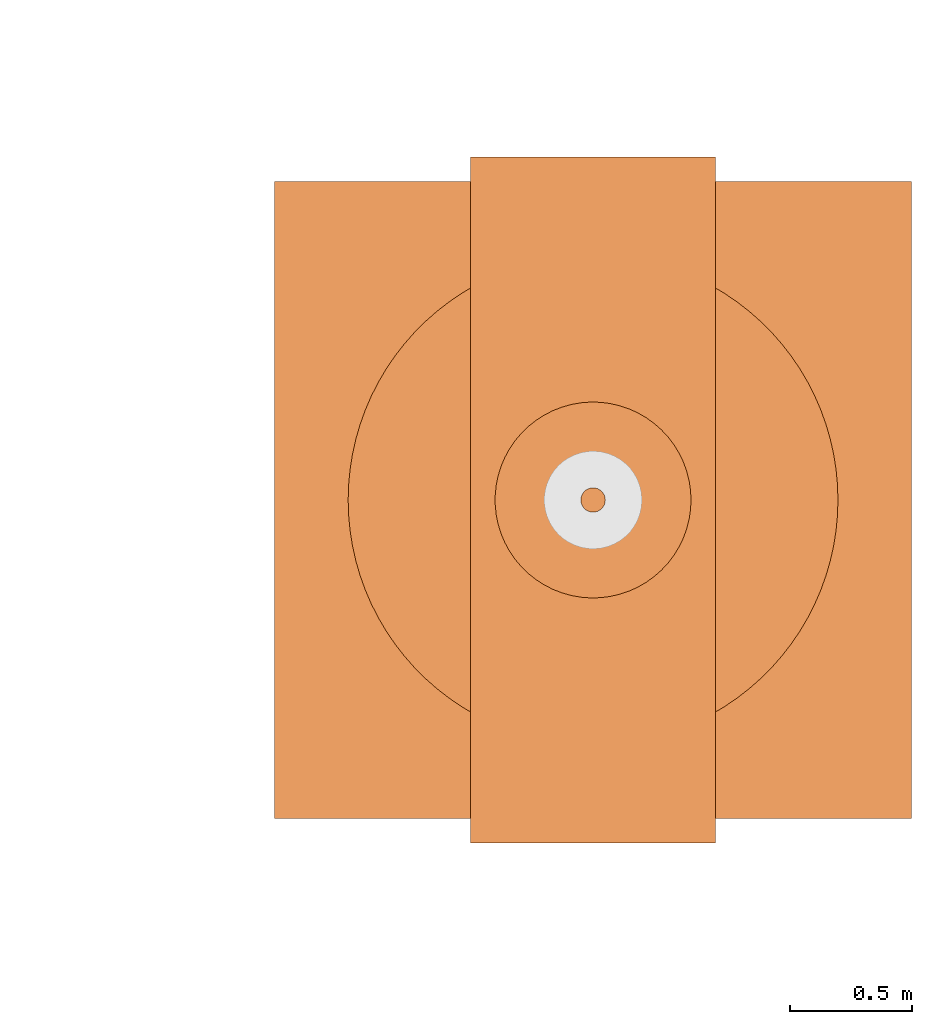
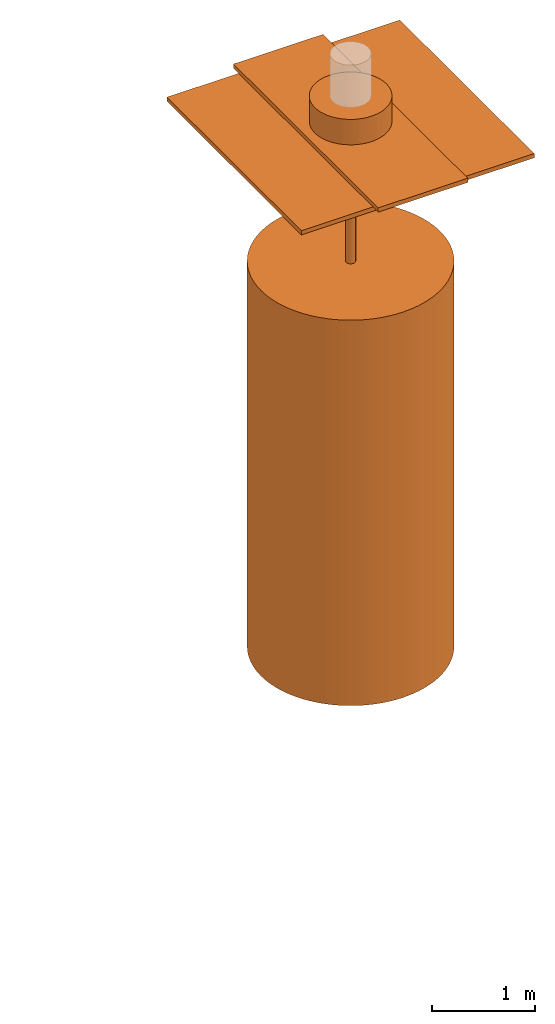
# One storey, part 3 of 6: 5 proxies.
"""IFC2X3 building model written with IfcOpenShell, lengths in millimetres."""

from ifc_helpers import new_model, entity, si_unit, converted_unit, direction, frame, origin_with_axes, origin_2d_with_axis, place, context, project, spatial, rectangle, circle, extrude, source, transform, mapped, element, save


model = new_model("IFC2X3")

# Units and contexts
model_context = context("Model", 3, precision=1e-05, world=origin_with_axes(), true_north=direction((0.0, 1.0)))
ifc_project = project(units=[si_unit("LENGTHUNIT", "METRE", prefix="MILLI"), si_unit("AREAUNIT", "SQUARE_METRE"), si_unit("VOLUMEUNIT", "CUBIC_METRE"), converted_unit("PLANEANGLEUNIT", "DEGREE", entity("IfcPlaneAngleMeasure", 0.017453293), si_unit("PLANEANGLEUNIT", "RADIAN"), dimensions=[0, 0, 0, 0, 0, 0, 0]), si_unit("SOLIDANGLEUNIT", "STERADIAN"), si_unit("MASSUNIT", "GRAM"), si_unit("TIMEUNIT", "SECOND"), si_unit("THERMODYNAMICTEMPERATUREUNIT", "DEGREE_CELSIUS"), si_unit("LUMINOUSINTENSITYUNIT", "LUMEN")], contexts=[model_context])

# Site, building, storey
site_placement = place(None, origin_with_axes())
site = spatial("IfcSite", under=ifc_project, at=site_placement, CompositionType="ELEMENT")
building_placement = place(site_placement, origin_with_axes())
building = spatial("IfcBuilding", under=site, at=building_placement, Name="Default Building", CompositionType="ELEMENT")
storey_placement = place(building_placement, frame((0.0, 0.0, 16000.0), z_axis=(0.0, 0.0, 1.0), x_axis=(1.0, 0.0, 0.0)))
storey = spatial("IfcBuildingStorey", under=building, at=storey_placement, Name="3FL", CompositionType="ELEMENT", Elevation=16000.0)

# Proxies
shared_shape_1 = source(origin_with_axes(), model_context, "Body", "SweptSolid", [
    extrude(circle(Radius=50.0, at=origin_2d_with_axis()), origin_with_axes(), (0.0, 0.0, 1.0), 1600.0),
])
proxy_1_placement = place(storey_placement, frame((73426.527192, 24003.281403, 4751.666314), z_axis=(0.0, 0.0, 1.0), x_axis=(1.0, 0.0, 0.0)))
element("IfcBuildingElementProxy", 1, at=proxy_1_placement, inside=storey, context=model_context, shape_type="MappedRepresentation", body=[
    mapped(shared_shape_1, transform((0.0, 0.0, 0.0))),
])
shared_shape_2 = source(origin_with_axes(), model_context, "Body", "SweptSolid", [
    extrude(circle(Radius=1000.0, at=origin_2d_with_axis()), origin_with_axes(), (0.0, 0.0, 1.0), 4550.0),
])
proxy_2_placement = place(storey_placement, frame((73426.527192, 24003.281403, 201.666314), z_axis=(0.0, 0.0, 1.0), x_axis=(1.0, 0.0, 0.0)))
element("IfcBuildingElementProxy", 2, at=proxy_2_placement, inside=storey, context=model_context, shape_type="MappedRepresentation", body=[
    mapped(shared_shape_2, transform((0.0, 0.0, 0.0))),
])
shared_shape_3 = source(origin_with_axes(), model_context, "Body", "SweptSolid", [
    extrude(rectangle(XDim=2600.0, YDim=2600.0, at=origin_2d_with_axis()), origin_with_axes(), (0.0, 0.0, 1.0), 50.0),
])
proxy_3_placement = place(storey_placement, frame((73426.527192, 24003.281403, 6301.666314), z_axis=(0.0, 0.0, 1.0), x_axis=(1.0, 0.0, 0.0)))
element("IfcBuildingElementProxy", 3, at=proxy_3_placement, inside=storey, context=model_context, shape_type="MappedRepresentation", body=[
    mapped(shared_shape_3, transform((0.0, 0.0, 0.0))),
])
shared_shape_4 = source(origin_with_axes(), model_context, "Body", "SweptSolid", [
    extrude(rectangle(XDim=1000.0, YDim=2800.0, at=origin_2d_with_axis()), origin_with_axes(), (0.0, 0.0, 1.0), 50.0),
])
proxy_4_placement = place(storey_placement, frame((73426.527192, 24003.281403, 6351.666314), z_axis=(0.0, 0.0, 1.0), x_axis=(1.0, 0.0, 0.0)))
element("IfcBuildingElementProxy", 4, at=proxy_4_placement, inside=storey, context=model_context, shape_type="MappedRepresentation", body=[
    mapped(shared_shape_4, transform((0.0, 0.0, 0.0))),
])
shared_shape_5 = source(origin_with_axes(), model_context, "Body", "SweptSolid", [
    extrude(circle(Radius=400.0, at=origin_2d_with_axis()), origin_with_axes(), (0.0, 0.0, 1.0), 300.0),
])
proxy_5_placement = place(storey_placement, frame((73426.527192, 24003.281403, 6401.666314), z_axis=(0.0, 0.0, 1.0), x_axis=(1.0, 0.0, 0.0)))
element("IfcBuildingElementProxy", 5, at=proxy_5_placement, inside=storey, context=model_context, shape_type="MappedRepresentation", body=[
    mapped(shared_shape_5, transform((0.0, 0.0, 0.0))),
])

save(model, "model.ifc")
